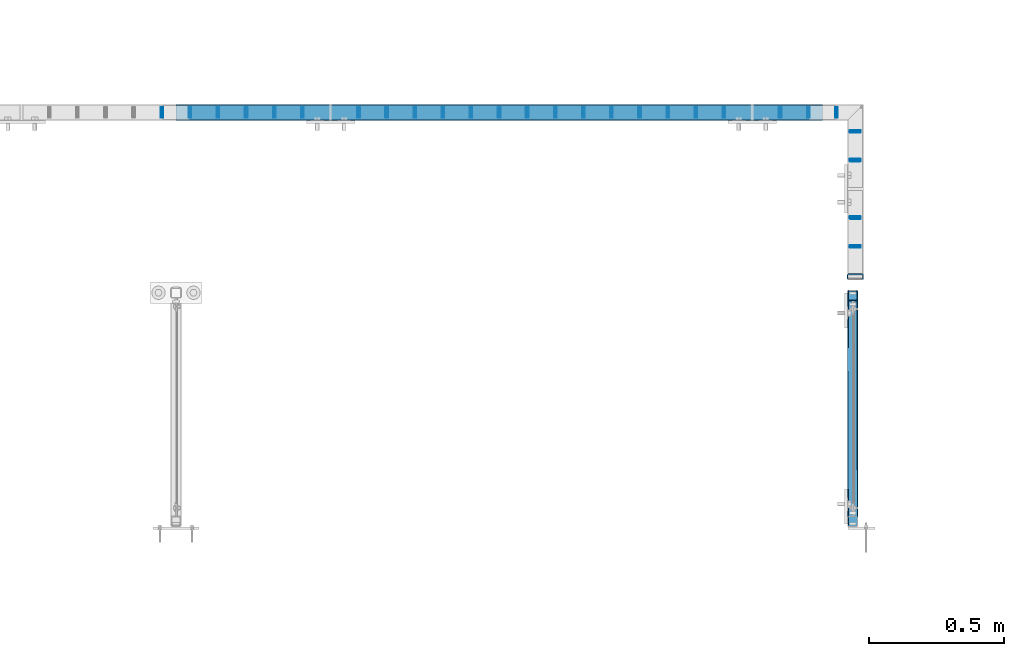
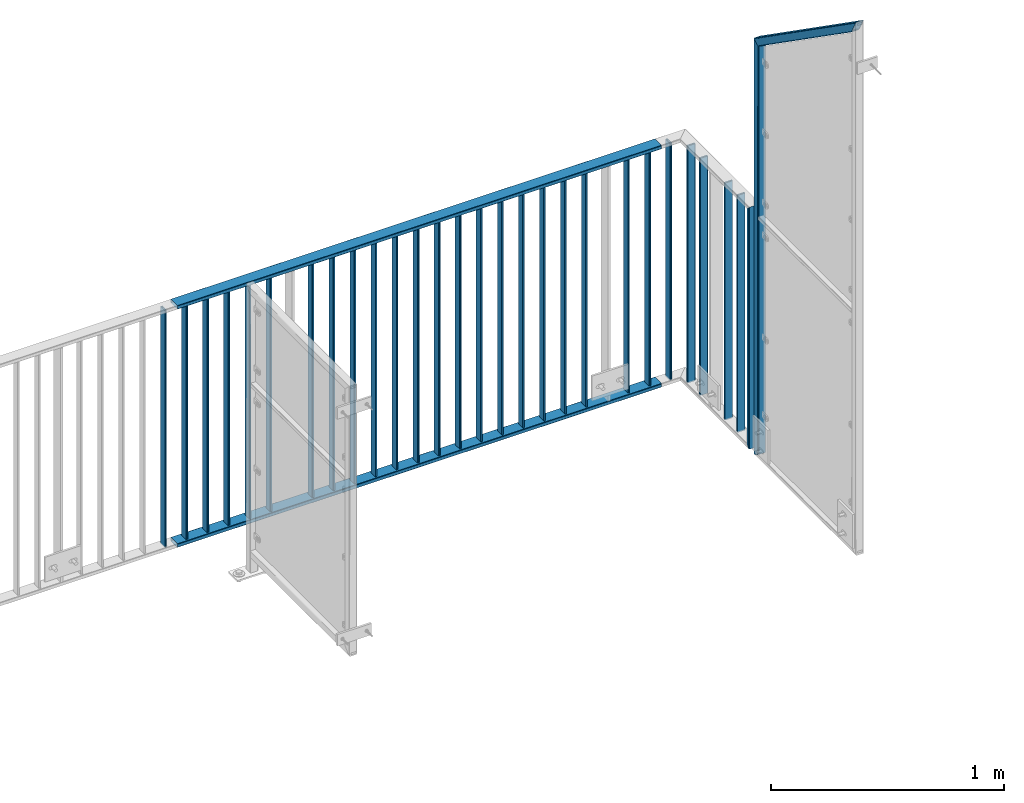
# One storey, part 35 of 156: 32 beams, 4 elements without a shape of their own.
"""IFC2X3 building model written with IfcOpenShell, lengths in millimetres."""

from ifc_helpers import new_model, si_unit, frame, origin_with_axes, origin_2d_with_axis, place, context, subcontext, project, spatial, hollow_rectangle, extrude, clip, halfspace, material, type_object, element, aggregate, save


model = new_model("IFC2X3")

# Units and contexts
model_context = context("Model", 3, precision=1e-05, world=origin_with_axes())
body_context = subcontext(model_context, "Body", "Model", "MODEL_VIEW")
ifc_project = project(units=[si_unit("LENGTHUNIT", "METRE", prefix="MILLI"), si_unit("AREAUNIT", "SQUARE_METRE"), si_unit("VOLUMEUNIT", "CUBIC_METRE"), si_unit("MASSUNIT", "GRAM", prefix="KILO"), si_unit("TIMEUNIT", "SECOND"), si_unit("PLANEANGLEUNIT", "RADIAN"), si_unit("SOLIDANGLEUNIT", "STERADIAN"), si_unit("THERMODYNAMICTEMPERATUREUNIT", "DEGREE_CELSIUS"), si_unit("LUMINOUSINTENSITYUNIT", "LUMEN")], contexts=[model_context])

# Site, building, storey
site_placement = place(None, origin_with_axes())
site = spatial("IfcSite", under=ifc_project, at=site_placement, CompositionType="ELEMENT")
building_placement = place(site_placement, origin_with_axes())
building = spatial("IfcBuilding", under=site, at=building_placement, Name="Undefined", CompositionType="ELEMENT")
storey_placement = place(building_placement, origin_with_axes())
storey = spatial("IfcBuildingStorey", under=building, at=storey_placement, Name="Undefined", CompositionType="ELEMENT", Elevation=0.0)

# Assembly, beam
assembly_1_placement = place(storey_placement, origin_with_axes())
assembly_1 = element("IfcElementAssembly", 1, at=assembly_1_placement, inside=storey, AssemblyPlace="NOTDEFINED", PredefinedType="RIGID_FRAME")
ifc_material = material(Name="STEEL/S235JR")
beam_type_1 = type_object("IfcBeamType", Name="K60/20/2", PredefinedType="NOTDEFINED")
beam_1_placement = place(assembly_1_placement, frame((46002.6731536865, 21657.990447998, 2740.0), z_axis=(0.0, -1.0, 0.0), x_axis=(-1.0, 0.0, 0.0)))
beam_1 = element("IfcBeam", 2, at=beam_1_placement, type_object=beam_type_1, material=ifc_material, ObjectType="K60/20/2", context=body_context, shape_type="SweptSolid", body=[
    extrude(hollow_rectangle(XDim=20.0, YDim=60.0, WallThickness=2.0, InnerFilletRadius=2.0, OuterFilletRadius=4.0, at=origin_2d_with_axis()), frame((2402.72054931641, 0.0, 0.0), z_axis=(-1.0, 0.0, 0.0), x_axis=(0.0, -1.0, 0.0)), (0.0, 0.0, 1.0), 2402.72),
])

assembly_2_placement = place(storey_placement, origin_with_axes())
assembly_2 = element("IfcElementAssembly", 3, at=assembly_2_placement, inside=storey, AssemblyPlace="NOTDEFINED", PredefinedType="RIGID_FRAME")
beam_2_placement = place(assembly_2_placement, frame((46124.9951324463, 21048.0001005923, 4000.0), z_axis=(-1.0, 0.0, 0.0), x_axis=(0.0, 0.0, -1.0)))
beam_2 = element("IfcBeam", 4, at=beam_2_placement, type_object=beam_type_1, material=ifc_material, ObjectType="K60/20/2", context=body_context, shape_type="Clipping", body=[
    clip(clip(extrude(hollow_rectangle(XDim=20.0, YDim=60.0, WallThickness=2.0, InnerFilletRadius=2.0, OuterFilletRadius=4.0, at=origin_2d_with_axis()), frame((1280.2, 0.0, 0.0), z_axis=(-1.0, 0.0, 0.0), x_axis=(0.0, -1.0, 0.0)), (0.0, 0.0, 1.0), 1290.4), halfspace(frame((1270.0, 10.0, 0.0), z_axis=(0.707106781186548, -0.707106781186548, 0.0), x_axis=(0.0, 0.0, -1.0)), False)), halfspace(frame((20.0, -10.0, 0.0), z_axis=(-0.707106781186548, -0.707106781186548, 0.0), x_axis=(0.0, 0.0, -1.0)), False)),
])

# Beam
beam_3_placement = place(assembly_1_placement, frame((46002.6731536865, 21657.990447998, 3990.0), z_axis=(0.0, -1.0, 0.0), x_axis=(-1.0, 0.0, 0.0)))
beam_3 = element("IfcBeam", 5, at=beam_3_placement, type_object=beam_type_1, material=ifc_material, ObjectType="K60/20/2", context=body_context, shape_type="SweptSolid", body=[
    extrude(hollow_rectangle(XDim=20.0, YDim=60.0, WallThickness=2.0, InnerFilletRadius=2.0, OuterFilletRadius=4.0, at=origin_2d_with_axis()), frame((2402.72054931641, 0.0, 0.0), z_axis=(-1.0, 0.0, 0.0), x_axis=(0.0, -1.0, 0.0)), (0.0, 0.0, 1.0), 2402.72),
])

beam_type_2 = type_object("IfcBeamType", Name="K40/10/1.5", PredefinedType="NOTDEFINED")
beam_4_placement = place(assembly_1_placement, frame((44279.0076043701, 21657.990447998, 3980.00000000003), z_axis=(0.0, -1.0, 0.0), x_axis=(0.0, 0.0, -1.0)))
beam_4 = element("IfcBeam", 6, at=beam_4_placement, type_object=beam_type_2, material=ifc_material, ObjectType="K40/10/1.5", context=body_context, shape_type="Clipping", body=[
    clip(clip(extrude(hollow_rectangle(XDim=10.0, YDim=40.0, WallThickness=1.5, InnerFilletRadius=1.5, OuterFilletRadius=3.0, at=origin_2d_with_axis()), frame((1237.00000000003, 0.0, 0.0), z_axis=(-1.0, 0.0, 0.0), x_axis=(0.0, -1.0, 0.0)), (0.0, 0.0, 1.0), 1244.0), halfspace(frame((1237.00000000003, 4.34248751949781, 47.3810900558092), z_axis=(1.0, 0.0, 0.0), x_axis=(0.0, -0.768354814194188, -0.640024124158313)), False)), halfspace(frame((-6.99999999997453, -4.34248751950508, 47.3810900558092), z_axis=(-1.0, 0.0, 0.0), x_axis=(0.0, 0.7683548141934, -0.640024124159258)), False)),
])

beam_5_placement = place(assembly_1_placement, frame((45846.0576043701, 21657.990447998, 3980.00000000003), z_axis=(0.0, -1.0, 0.0), x_axis=(0.0, 0.0, -1.0)))
beam_5 = element("IfcBeam", 7, at=beam_5_placement, type_object=beam_type_2, material=ifc_material, ObjectType="K40/10/1.5", context=body_context, shape_type="Clipping", body=[
    clip(clip(extrude(hollow_rectangle(XDim=10.0, YDim=40.0, WallThickness=1.5, InnerFilletRadius=1.5, OuterFilletRadius=3.0, at=origin_2d_with_axis()), frame((1237.00000000003, 0.0, 0.0), z_axis=(-1.0, 0.0, 0.0), x_axis=(0.0, -1.0, 0.0)), (0.0, 0.0, 1.0), 1244.0), halfspace(frame((1237.00000000003, 4.34248751949781, 47.3810900558092), z_axis=(1.0, 0.0, 0.0), x_axis=(0.0, -0.768354814194188, -0.640024124158313)), False)), halfspace(frame((-6.99999999997453, -4.34248751950508, 47.3810900558092), z_axis=(-1.0, 0.0, 0.0), x_axis=(0.0, 0.7683548141934, -0.640024124159258)), False)),
])

# Assembly, beam
assembly_3_placement = place(storey_placement, origin_with_axes())
assembly_3 = element("IfcElementAssembly", 8, at=assembly_3_placement, inside=storey, AssemblyPlace="NOTDEFINED", PredefinedType="RIGID_FRAME")
beam_6_placement = place(assembly_3_placement, frame((43547.7176043701, 21657.990447998, 3980.00000000003), z_axis=(0.0, -1.0, 0.0), x_axis=(0.0, 0.0, -1.0)))
beam_6 = element("IfcBeam", 9, at=beam_6_placement, type_object=beam_type_2, material=ifc_material, ObjectType="K40/10/1.5", context=body_context, shape_type="Clipping", body=[
    clip(clip(extrude(hollow_rectangle(XDim=10.0, YDim=40.0, WallThickness=1.5, InnerFilletRadius=1.5, OuterFilletRadius=3.0, at=origin_2d_with_axis()), frame((1237.00000000003, 0.0, 0.0), z_axis=(-1.0, 0.0, 0.0), x_axis=(0.0, -1.0, 0.0)), (0.0, 0.0, 1.0), 1244.0), halfspace(frame((1237.00000000003, 4.34248751949781, 47.3810900558092), z_axis=(1.0, 0.0, 0.0), x_axis=(0.0, -0.768354814194188, -0.640024124158313)), False)), halfspace(frame((-6.99999999997453, -4.34248751950508, 47.3810900558092), z_axis=(-1.0, 0.0, 0.0), x_axis=(0.0, 0.7683548141934, -0.640024124159258)), False)),
])
aggregate(assembly_3, [beam_6])

# Beam
beam_7_placement = place(assembly_1_placement, frame((43652.1876043701, 21657.990447998, 3980.00000000003), z_axis=(0.0, -1.0, 0.0), x_axis=(0.0, 0.0, -1.0)))
beam_7 = element("IfcBeam", 10, at=beam_7_placement, type_object=beam_type_2, material=ifc_material, ObjectType="K40/10/1.5", context=body_context, shape_type="Clipping", body=[
    clip(clip(extrude(hollow_rectangle(XDim=10.0, YDim=40.0, WallThickness=1.5, InnerFilletRadius=1.5, OuterFilletRadius=3.0, at=origin_2d_with_axis()), frame((1237.00000000003, 0.0, 0.0), z_axis=(-1.0, 0.0, 0.0), x_axis=(0.0, -1.0, 0.0)), (0.0, 0.0, 1.0), 1244.0), halfspace(frame((1237.00000000003, 4.34248751949781, 47.3810900558092), z_axis=(1.0, 0.0, 0.0), x_axis=(0.0, -0.768354814194188, -0.640024124158313)), False)), halfspace(frame((-6.99999999997453, -4.34248751950508, 47.3810900558092), z_axis=(-1.0, 0.0, 0.0), x_axis=(0.0, 0.7683548141934, -0.640024124159258)), False)),
])

beam_8_placement = place(assembly_1_placement, frame((43756.6576043701, 21657.990447998, 3980.00000000003), z_axis=(0.0, -1.0, 0.0), x_axis=(0.0, 0.0, -1.0)))
beam_8 = element("IfcBeam", 11, at=beam_8_placement, type_object=beam_type_2, material=ifc_material, ObjectType="K40/10/1.5", context=body_context, shape_type="Clipping", body=[
    clip(clip(extrude(hollow_rectangle(XDim=10.0, YDim=40.0, WallThickness=1.5, InnerFilletRadius=1.5, OuterFilletRadius=3.0, at=origin_2d_with_axis()), frame((1237.00000000003, 0.0, 0.0), z_axis=(-1.0, 0.0, 0.0), x_axis=(0.0, -1.0, 0.0)), (0.0, 0.0, 1.0), 1244.0), halfspace(frame((1237.00000000003, 4.34248751949781, 47.3810900558092), z_axis=(1.0, 0.0, 0.0), x_axis=(0.0, -0.768354814194188, -0.640024124158313)), False)), halfspace(frame((-6.99999999997453, -4.34248751950508, 47.3810900558092), z_axis=(-1.0, 0.0, 0.0), x_axis=(0.0, 0.7683548141934, -0.640024124159258)), False)),
])

beam_9_placement = place(assembly_1_placement, frame((43861.1276043701, 21657.990447998, 3980.00000000003), z_axis=(0.0, -1.0, 0.0), x_axis=(0.0, 0.0, -1.0)))
beam_9 = element("IfcBeam", 12, at=beam_9_placement, type_object=beam_type_2, material=ifc_material, ObjectType="K40/10/1.5", context=body_context, shape_type="Clipping", body=[
    clip(clip(extrude(hollow_rectangle(XDim=10.0, YDim=40.0, WallThickness=1.5, InnerFilletRadius=1.5, OuterFilletRadius=3.0, at=origin_2d_with_axis()), frame((1237.00000000003, 0.0, 0.0), z_axis=(-1.0, 0.0, 0.0), x_axis=(0.0, -1.0, 0.0)), (0.0, 0.0, 1.0), 1244.0), halfspace(frame((1237.00000000003, 4.34248751949781, 47.3810900558092), z_axis=(1.0, 0.0, 0.0), x_axis=(0.0, -0.768354814194188, -0.640024124158313)), False)), halfspace(frame((-6.99999999997453, -4.34248751950508, 47.3810900558092), z_axis=(-1.0, 0.0, 0.0), x_axis=(0.0, 0.7683548141934, -0.640024124159258)), False)),
])

beam_10_placement = place(assembly_1_placement, frame((43965.5976043701, 21657.990447998, 3980.00000000003), z_axis=(0.0, -1.0, 0.0), x_axis=(0.0, 0.0, -1.0)))
beam_10 = element("IfcBeam", 13, at=beam_10_placement, type_object=beam_type_2, material=ifc_material, ObjectType="K40/10/1.5", context=body_context, shape_type="Clipping", body=[
    clip(clip(extrude(hollow_rectangle(XDim=10.0, YDim=40.0, WallThickness=1.5, InnerFilletRadius=1.5, OuterFilletRadius=3.0, at=origin_2d_with_axis()), frame((1237.00000000003, 0.0, 0.0), z_axis=(-1.0, 0.0, 0.0), x_axis=(0.0, -1.0, 0.0)), (0.0, 0.0, 1.0), 1244.0), halfspace(frame((1237.00000000003, 4.34248751949781, 47.3810900558092), z_axis=(1.0, 0.0, 0.0), x_axis=(0.0, -0.768354814194188, -0.640024124158313)), False)), halfspace(frame((-6.99999999997453, -4.34248751950508, 47.3810900558092), z_axis=(-1.0, 0.0, 0.0), x_axis=(0.0, 0.7683548141934, -0.640024124159258)), False)),
])

beam_11_placement = place(assembly_1_placement, frame((44070.0676043701, 21657.990447998, 3980.00000000003), z_axis=(0.0, -1.0, 0.0), x_axis=(0.0, 0.0, -1.0)))
beam_11 = element("IfcBeam", 14, at=beam_11_placement, type_object=beam_type_2, material=ifc_material, ObjectType="K40/10/1.5", context=body_context, shape_type="Clipping", body=[
    clip(clip(extrude(hollow_rectangle(XDim=10.0, YDim=40.0, WallThickness=1.5, InnerFilletRadius=1.5, OuterFilletRadius=3.0, at=origin_2d_with_axis()), frame((1237.00000000003, 0.0, 0.0), z_axis=(-1.0, 0.0, 0.0), x_axis=(0.0, -1.0, 0.0)), (0.0, 0.0, 1.0), 1244.0), halfspace(frame((1237.00000000003, 4.34248751949781, 47.3810900558092), z_axis=(1.0, 0.0, 0.0), x_axis=(0.0, -0.768354814194188, -0.640024124158313)), False)), halfspace(frame((-6.99999999997453, -4.34248751950508, 47.3810900558092), z_axis=(-1.0, 0.0, 0.0), x_axis=(0.0, 0.7683548141934, -0.640024124159258)), False)),
])

beam_12_placement = place(assembly_1_placement, frame((44383.4776043701, 21657.990447998, 3980.00000000003), z_axis=(0.0, -1.0, 0.0), x_axis=(0.0, 0.0, -1.0)))
beam_12 = element("IfcBeam", 15, at=beam_12_placement, type_object=beam_type_2, material=ifc_material, ObjectType="K40/10/1.5", context=body_context, shape_type="Clipping", body=[
    clip(clip(extrude(hollow_rectangle(XDim=10.0, YDim=40.0, WallThickness=1.5, InnerFilletRadius=1.5, OuterFilletRadius=3.0, at=origin_2d_with_axis()), frame((1237.00000000003, 0.0, 0.0), z_axis=(-1.0, 0.0, 0.0), x_axis=(0.0, -1.0, 0.0)), (0.0, 0.0, 1.0), 1244.0), halfspace(frame((1237.00000000003, 4.34248751949781, 47.3810900558092), z_axis=(1.0, 0.0, 0.0), x_axis=(0.0, -0.768354814194188, -0.640024124158313)), False)), halfspace(frame((-6.99999999997453, -4.34248751950508, 47.3810900558092), z_axis=(-1.0, 0.0, 0.0), x_axis=(0.0, 0.7683548141934, -0.640024124159258)), False)),
])

beam_13_placement = place(assembly_1_placement, frame((44487.9476043701, 21657.990447998, 3980.00000000003), z_axis=(0.0, -1.0, 0.0), x_axis=(0.0, 0.0, -1.0)))
beam_13 = element("IfcBeam", 16, at=beam_13_placement, type_object=beam_type_2, material=ifc_material, ObjectType="K40/10/1.5", context=body_context, shape_type="Clipping", body=[
    clip(clip(extrude(hollow_rectangle(XDim=10.0, YDim=40.0, WallThickness=1.5, InnerFilletRadius=1.5, OuterFilletRadius=3.0, at=origin_2d_with_axis()), frame((1237.00000000003, 0.0, 0.0), z_axis=(-1.0, 0.0, 0.0), x_axis=(0.0, -1.0, 0.0)), (0.0, 0.0, 1.0), 1244.0), halfspace(frame((1237.00000000003, 4.34248751949781, 47.3810900558092), z_axis=(1.0, 0.0, 0.0), x_axis=(0.0, -0.768354814194188, -0.640024124158313)), False)), halfspace(frame((-6.99999999997453, -4.34248751950508, 47.3810900558092), z_axis=(-1.0, 0.0, 0.0), x_axis=(0.0, 0.7683548141934, -0.640024124159258)), False)),
])

beam_14_placement = place(assembly_1_placement, frame((44592.4176043701, 21657.990447998, 3980.00000000003), z_axis=(0.0, -1.0, 0.0), x_axis=(0.0, 0.0, -1.0)))
beam_14 = element("IfcBeam", 17, at=beam_14_placement, type_object=beam_type_2, material=ifc_material, ObjectType="K40/10/1.5", context=body_context, shape_type="Clipping", body=[
    clip(clip(extrude(hollow_rectangle(XDim=10.0, YDim=40.0, WallThickness=1.5, InnerFilletRadius=1.5, OuterFilletRadius=3.0, at=origin_2d_with_axis()), frame((1237.00000000003, 0.0, 0.0), z_axis=(-1.0, 0.0, 0.0), x_axis=(0.0, -1.0, 0.0)), (0.0, 0.0, 1.0), 1244.0), halfspace(frame((1237.00000000003, 4.34248751949781, 47.3810900558092), z_axis=(1.0, 0.0, 0.0), x_axis=(0.0, -0.768354814194188, -0.640024124158313)), False)), halfspace(frame((-6.99999999997453, -4.34248751950508, 47.3810900558092), z_axis=(-1.0, 0.0, 0.0), x_axis=(0.0, 0.7683548141934, -0.640024124159258)), False)),
])

beam_15_placement = place(assembly_1_placement, frame((44696.8876043701, 21657.990447998, 3980.00000000003), z_axis=(0.0, -1.0, 0.0), x_axis=(0.0, 0.0, -1.0)))
beam_15 = element("IfcBeam", 18, at=beam_15_placement, type_object=beam_type_2, material=ifc_material, ObjectType="K40/10/1.5", context=body_context, shape_type="Clipping", body=[
    clip(clip(extrude(hollow_rectangle(XDim=10.0, YDim=40.0, WallThickness=1.5, InnerFilletRadius=1.5, OuterFilletRadius=3.0, at=origin_2d_with_axis()), frame((1237.00000000003, 0.0, 0.0), z_axis=(-1.0, 0.0, 0.0), x_axis=(0.0, -1.0, 0.0)), (0.0, 0.0, 1.0), 1244.0), halfspace(frame((1237.00000000003, 4.34248751949781, 47.3810900558092), z_axis=(1.0, 0.0, 0.0), x_axis=(0.0, -0.768354814194188, -0.640024124158313)), False)), halfspace(frame((-6.99999999997453, -4.34248751950508, 47.3810900558092), z_axis=(-1.0, 0.0, 0.0), x_axis=(0.0, 0.7683548141934, -0.640024124159258)), False)),
])

beam_16_placement = place(assembly_1_placement, frame((44801.3576043701, 21657.990447998, 3980.00000000003), z_axis=(0.0, -1.0, 0.0), x_axis=(0.0, 0.0, -1.0)))
beam_16 = element("IfcBeam", 19, at=beam_16_placement, type_object=beam_type_2, material=ifc_material, ObjectType="K40/10/1.5", context=body_context, shape_type="Clipping", body=[
    clip(clip(extrude(hollow_rectangle(XDim=10.0, YDim=40.0, WallThickness=1.5, InnerFilletRadius=1.5, OuterFilletRadius=3.0, at=origin_2d_with_axis()), frame((1237.00000000003, 0.0, 0.0), z_axis=(-1.0, 0.0, 0.0), x_axis=(0.0, -1.0, 0.0)), (0.0, 0.0, 1.0), 1244.0), halfspace(frame((1237.00000000003, 4.34248751949781, 47.3810900558092), z_axis=(1.0, 0.0, 0.0), x_axis=(0.0, -0.768354814194188, -0.640024124158313)), False)), halfspace(frame((-6.99999999997453, -4.34248751950508, 47.3810900558092), z_axis=(-1.0, 0.0, 0.0), x_axis=(0.0, 0.7683548141934, -0.640024124159258)), False)),
])

beam_17_placement = place(assembly_1_placement, frame((44905.8276043701, 21657.990447998, 3980.00000000003), z_axis=(0.0, -1.0, 0.0), x_axis=(0.0, 0.0, -1.0)))
beam_17 = element("IfcBeam", 20, at=beam_17_placement, type_object=beam_type_2, material=ifc_material, ObjectType="K40/10/1.5", context=body_context, shape_type="Clipping", body=[
    clip(clip(extrude(hollow_rectangle(XDim=10.0, YDim=40.0, WallThickness=1.5, InnerFilletRadius=1.5, OuterFilletRadius=3.0, at=origin_2d_with_axis()), frame((1237.00000000003, 0.0, 0.0), z_axis=(-1.0, 0.0, 0.0), x_axis=(0.0, -1.0, 0.0)), (0.0, 0.0, 1.0), 1244.0), halfspace(frame((1237.00000000003, 4.34248751949781, 47.3810900558092), z_axis=(1.0, 0.0, 0.0), x_axis=(0.0, -0.768354814194188, -0.640024124158313)), False)), halfspace(frame((-6.99999999997453, -4.34248751950508, 47.3810900558092), z_axis=(-1.0, 0.0, 0.0), x_axis=(0.0, 0.7683548141934, -0.640024124159258)), False)),
])

beam_18_placement = place(assembly_1_placement, frame((45010.2976043701, 21657.990447998, 3980.00000000003), z_axis=(0.0, -1.0, 0.0), x_axis=(0.0, 0.0, -1.0)))
beam_18 = element("IfcBeam", 21, at=beam_18_placement, type_object=beam_type_2, material=ifc_material, ObjectType="K40/10/1.5", context=body_context, shape_type="Clipping", body=[
    clip(clip(extrude(hollow_rectangle(XDim=10.0, YDim=40.0, WallThickness=1.5, InnerFilletRadius=1.5, OuterFilletRadius=3.0, at=origin_2d_with_axis()), frame((1237.00000000003, 0.0, 0.0), z_axis=(-1.0, 0.0, 0.0), x_axis=(0.0, -1.0, 0.0)), (0.0, 0.0, 1.0), 1244.0), halfspace(frame((1237.00000000003, 4.34248751949781, 47.3810900558092), z_axis=(1.0, 0.0, 0.0), x_axis=(0.0, -0.768354814194188, -0.640024124158313)), False)), halfspace(frame((-6.99999999997453, -4.34248751950508, 47.3810900558092), z_axis=(-1.0, 0.0, 0.0), x_axis=(0.0, 0.7683548141934, -0.640024124159258)), False)),
])

beam_19_placement = place(assembly_1_placement, frame((45114.7676043701, 21657.990447998, 3980.00000000003), z_axis=(0.0, -1.0, 0.0), x_axis=(0.0, 0.0, -1.0)))
beam_19 = element("IfcBeam", 22, at=beam_19_placement, type_object=beam_type_2, material=ifc_material, ObjectType="K40/10/1.5", context=body_context, shape_type="Clipping", body=[
    clip(clip(extrude(hollow_rectangle(XDim=10.0, YDim=40.0, WallThickness=1.5, InnerFilletRadius=1.5, OuterFilletRadius=3.0, at=origin_2d_with_axis()), frame((1237.00000000003, 0.0, 0.0), z_axis=(-1.0, 0.0, 0.0), x_axis=(0.0, -1.0, 0.0)), (0.0, 0.0, 1.0), 1244.0), halfspace(frame((1237.00000000003, 4.34248751949781, 47.3810900558092), z_axis=(1.0, 0.0, 0.0), x_axis=(0.0, -0.768354814194188, -0.640024124158313)), False)), halfspace(frame((-6.99999999997453, -4.34248751950508, 47.3810900558092), z_axis=(-1.0, 0.0, 0.0), x_axis=(0.0, 0.7683548141934, -0.640024124159258)), False)),
])

beam_20_placement = place(assembly_1_placement, frame((45219.2376043701, 21657.990447998, 3980.00000000003), z_axis=(0.0, -1.0, 0.0), x_axis=(0.0, 0.0, -1.0)))
beam_20 = element("IfcBeam", 23, at=beam_20_placement, type_object=beam_type_2, material=ifc_material, ObjectType="K40/10/1.5", context=body_context, shape_type="Clipping", body=[
    clip(clip(extrude(hollow_rectangle(XDim=10.0, YDim=40.0, WallThickness=1.5, InnerFilletRadius=1.5, OuterFilletRadius=3.0, at=origin_2d_with_axis()), frame((1237.00000000003, 0.0, 0.0), z_axis=(-1.0, 0.0, 0.0), x_axis=(0.0, -1.0, 0.0)), (0.0, 0.0, 1.0), 1244.0), halfspace(frame((1237.00000000003, 4.34248751949781, 47.3810900558092), z_axis=(1.0, 0.0, 0.0), x_axis=(0.0, -0.768354814194188, -0.640024124158313)), False)), halfspace(frame((-6.99999999997453, -4.34248751950508, 47.3810900558092), z_axis=(-1.0, 0.0, 0.0), x_axis=(0.0, 0.7683548141934, -0.640024124159258)), False)),
])

beam_21_placement = place(assembly_1_placement, frame((45323.7076043701, 21657.990447998, 3980.00000000003), z_axis=(0.0, -1.0, 0.0), x_axis=(0.0, 0.0, -1.0)))
beam_21 = element("IfcBeam", 24, at=beam_21_placement, type_object=beam_type_2, material=ifc_material, ObjectType="K40/10/1.5", context=body_context, shape_type="Clipping", body=[
    clip(clip(extrude(hollow_rectangle(XDim=10.0, YDim=40.0, WallThickness=1.5, InnerFilletRadius=1.5, OuterFilletRadius=3.0, at=origin_2d_with_axis()), frame((1237.00000000003, 0.0, 0.0), z_axis=(-1.0, 0.0, 0.0), x_axis=(0.0, -1.0, 0.0)), (0.0, 0.0, 1.0), 1244.0), halfspace(frame((1237.00000000003, 4.34248751949781, 47.3810900558092), z_axis=(1.0, 0.0, 0.0), x_axis=(0.0, -0.768354814194188, -0.640024124158313)), False)), halfspace(frame((-6.99999999997453, -4.34248751950508, 47.3810900558092), z_axis=(-1.0, 0.0, 0.0), x_axis=(0.0, 0.7683548141934, -0.640024124159258)), False)),
])

beam_22_placement = place(assembly_1_placement, frame((45428.1776043701, 21657.990447998, 3980.00000000003), z_axis=(0.0, -1.0, 0.0), x_axis=(0.0, 0.0, -1.0)))
beam_22 = element("IfcBeam", 25, at=beam_22_placement, type_object=beam_type_2, material=ifc_material, ObjectType="K40/10/1.5", context=body_context, shape_type="Clipping", body=[
    clip(clip(extrude(hollow_rectangle(XDim=10.0, YDim=40.0, WallThickness=1.5, InnerFilletRadius=1.5, OuterFilletRadius=3.0, at=origin_2d_with_axis()), frame((1237.00000000003, 0.0, 0.0), z_axis=(-1.0, 0.0, 0.0), x_axis=(0.0, -1.0, 0.0)), (0.0, 0.0, 1.0), 1244.0), halfspace(frame((1237.00000000003, 4.34248751949781, 47.3810900558092), z_axis=(1.0, 0.0, 0.0), x_axis=(0.0, -0.768354814194188, -0.640024124158313)), False)), halfspace(frame((-6.99999999997453, -4.34248751950508, 47.3810900558092), z_axis=(-1.0, 0.0, 0.0), x_axis=(0.0, 0.7683548141934, -0.640024124159258)), False)),
])

beam_23_placement = place(assembly_1_placement, frame((45532.6476043701, 21657.990447998, 3980.00000000003), z_axis=(0.0, -1.0, 0.0), x_axis=(0.0, 0.0, -1.0)))
beam_23 = element("IfcBeam", 26, at=beam_23_placement, type_object=beam_type_2, material=ifc_material, ObjectType="K40/10/1.5", context=body_context, shape_type="Clipping", body=[
    clip(clip(extrude(hollow_rectangle(XDim=10.0, YDim=40.0, WallThickness=1.5, InnerFilletRadius=1.5, OuterFilletRadius=3.0, at=origin_2d_with_axis()), frame((1237.00000000003, 0.0, 0.0), z_axis=(-1.0, 0.0, 0.0), x_axis=(0.0, -1.0, 0.0)), (0.0, 0.0, 1.0), 1244.0), halfspace(frame((1237.00000000003, 4.34248751949781, 47.3810900558092), z_axis=(1.0, 0.0, 0.0), x_axis=(0.0, -0.768354814194188, -0.640024124158313)), False)), halfspace(frame((-6.99999999997453, -4.34248751950508, 47.3810900558092), z_axis=(-1.0, 0.0, 0.0), x_axis=(0.0, 0.7683548141934, -0.640024124159258)), False)),
])

beam_24_placement = place(assembly_1_placement, frame((45637.1176043701, 21657.990447998, 3980.00000000003), z_axis=(0.0, -1.0, 0.0), x_axis=(0.0, 0.0, -1.0)))
beam_24 = element("IfcBeam", 27, at=beam_24_placement, type_object=beam_type_2, material=ifc_material, ObjectType="K40/10/1.5", context=body_context, shape_type="Clipping", body=[
    clip(clip(extrude(hollow_rectangle(XDim=10.0, YDim=40.0, WallThickness=1.5, InnerFilletRadius=1.5, OuterFilletRadius=3.0, at=origin_2d_with_axis()), frame((1237.00000000003, 0.0, 0.0), z_axis=(-1.0, 0.0, 0.0), x_axis=(0.0, -1.0, 0.0)), (0.0, 0.0, 1.0), 1244.0), halfspace(frame((1237.00000000003, 4.34248751949781, 47.3810900558092), z_axis=(1.0, 0.0, 0.0), x_axis=(0.0, -0.768354814194188, -0.640024124158313)), False)), halfspace(frame((-6.99999999997453, -4.34248751950508, 47.3810900558092), z_axis=(-1.0, 0.0, 0.0), x_axis=(0.0, 0.7683548141934, -0.640024124159258)), False)),
])

beam_25_placement = place(assembly_1_placement, frame((45950.5276043701, 21657.990447998, 3980.00000000003), z_axis=(0.0, -1.0, 0.0), x_axis=(0.0, 0.0, -1.0)))
beam_25 = element("IfcBeam", 28, at=beam_25_placement, type_object=beam_type_2, material=ifc_material, ObjectType="K40/10/1.5", context=body_context, shape_type="Clipping", body=[
    clip(clip(extrude(hollow_rectangle(XDim=10.0, YDim=40.0, WallThickness=1.5, InnerFilletRadius=1.5, OuterFilletRadius=3.0, at=origin_2d_with_axis()), frame((1237.00000000003, 0.0, 0.0), z_axis=(-1.0, 0.0, 0.0), x_axis=(0.0, -1.0, 0.0)), (0.0, 0.0, 1.0), 1244.0), halfspace(frame((1237.00000000003, 4.28697690345871, 47.3348312091512), z_axis=(1.0, 0.0, 0.0), x_axis=(0.0, -0.763991285051099, -0.645226562043109)), False)), halfspace(frame((-6.99999999997453, -4.28697690345871, 47.3348312091512), z_axis=(-1.0, 0.0, 0.0), x_axis=(0.0, 0.763991285051099, -0.645226562043109)), False)),
])

aggregate(assembly_1, [beam_1, beam_4, beam_5, beam_7, beam_8, beam_9, beam_10, beam_11, beam_12, beam_13, beam_14, beam_15, beam_16, beam_17, beam_18, beam_19, beam_20, beam_21, beam_22, beam_23, beam_24, beam_25, beam_3])

beam_26_placement = place(assembly_2_placement, frame((46124.9972914954, 21160.3092182564, 3980.00000000003), z_axis=(-1.0, 0.0, 0.0), x_axis=(0.0, 0.0, -1.0)))
beam_26 = element("IfcBeam", 29, at=beam_26_placement, type_object=beam_type_2, material=ifc_material, ObjectType="K40/10/1.5", context=body_context, shape_type="Clipping", body=[
    clip(clip(extrude(hollow_rectangle(XDim=10.0, YDim=40.0, WallThickness=1.5, InnerFilletRadius=1.5, OuterFilletRadius=3.0, at=origin_2d_with_axis()), frame((1237.00000000003, 0.0, 0.0), z_axis=(-1.0, 0.0, 0.0), x_axis=(0.0, -1.0, 0.0)), (0.0, 0.0, 1.0), 1244.0), halfspace(frame((1237.00000000003, 3.2449841921989, 46.4665039507236), z_axis=(1.0, 0.0, 0.0), x_axis=(0.0, -0.754414263122933, -0.656398598106883)), False)), halfspace(frame((-6.99999999997453, -2.66359292875859, 45.9820112315028), z_axis=(-1.0, 0.0, 0.0), x_axis=(0.0, 0.747680594279002, -0.664058528247773)), False)),
])

beam_27_placement = place(assembly_2_placement, frame((46124.9972914954, 21267.2292182564, 3980.00000000003), z_axis=(-1.0, 0.0, 0.0), x_axis=(0.0, 0.0, -1.0)))
beam_27 = element("IfcBeam", 30, at=beam_27_placement, type_object=beam_type_2, material=ifc_material, ObjectType="K40/10/1.5", context=body_context, shape_type="Clipping", body=[
    clip(clip(extrude(hollow_rectangle(XDim=10.0, YDim=40.0, WallThickness=1.5, InnerFilletRadius=1.5, OuterFilletRadius=3.0, at=origin_2d_with_axis()), frame((1237.00000000003, 0.0, 0.0), z_axis=(-1.0, 0.0, 0.0), x_axis=(0.0, -1.0, 0.0)), (0.0, 0.0, 1.0), 1244.0), halfspace(frame((1237.00000000003, 2.66359292875859, 45.9820112315028), z_axis=(1.0, 0.0, 0.0), x_axis=(0.0, -0.747680594278991, -0.664058528247785)), False)), halfspace(frame((-6.99999999997453, -2.66359292875859, 45.9820112315028), z_axis=(-1.0, 0.0, 0.0), x_axis=(0.0, 0.747680594279002, -0.664058528247773)), False)),
])

beam_28_placement = place(assembly_2_placement, frame((46124.9972914954, 21481.0692182564, 3980.00000000003), z_axis=(-1.0, 0.0, 0.0), x_axis=(0.0, 0.0, -1.0)))
beam_28 = element("IfcBeam", 31, at=beam_28_placement, type_object=beam_type_2, material=ifc_material, ObjectType="K40/10/1.5", context=body_context, shape_type="Clipping", body=[
    clip(clip(extrude(hollow_rectangle(XDim=10.0, YDim=40.0, WallThickness=1.5, InnerFilletRadius=1.5, OuterFilletRadius=3.0, at=origin_2d_with_axis()), frame((1237.00000000003, 0.0, 0.0), z_axis=(-1.0, 0.0, 0.0), x_axis=(0.0, -1.0, 0.0)), (0.0, 0.0, 1.0), 1244.0), halfspace(frame((1237.00000000003, 2.66359292875859, 45.9820112315028), z_axis=(1.0, 0.0, 0.0), x_axis=(0.0, -0.747680594278991, -0.664058528247785)), False)), halfspace(frame((-6.99999999997453, -2.66359292875859, 45.9820112315028), z_axis=(-1.0, 0.0, 0.0), x_axis=(0.0, 0.747680594279002, -0.664058528247773)), False)),
])

beam_29_placement = place(assembly_2_placement, frame((46054.9976043701, 21657.990447998, 3980.00000000003), z_axis=(0.0, -1.0, 0.0), x_axis=(0.0, 0.0, -1.0)))
beam_29 = element("IfcBeam", 32, at=beam_29_placement, type_object=beam_type_2, material=ifc_material, ObjectType="K40/10/1.5", context=body_context, shape_type="Clipping", body=[
    clip(clip(extrude(hollow_rectangle(XDim=10.0, YDim=40.0, WallThickness=1.5, InnerFilletRadius=1.5, OuterFilletRadius=3.0, at=origin_2d_with_axis()), frame((1237.00000000003, 0.0, 0.0), z_axis=(-1.0, 0.0, 0.0), x_axis=(0.0, -1.0, 0.0)), (0.0, 0.0, 1.0), 1244.0), halfspace(frame((1237.00000000003, 4.34248751949781, 47.3810900558092), z_axis=(1.0, 0.0, 0.0), x_axis=(0.0, -0.763991285051099, -0.645226562043109)), False)), halfspace(frame((-6.99999999997453, -4.34248751950508, 47.3810900558092), z_axis=(-1.0, 0.0, 0.0), x_axis=(0.0, 0.763991285051099, -0.645226562043109)), False)),
])

beam_30_placement = place(assembly_2_placement, frame((46124.9972914954, 21587.9892182564, 3980.00000000003), z_axis=(-1.0, 0.0, 0.0), x_axis=(0.0, 0.0, -1.0)))
beam_30 = element("IfcBeam", 33, at=beam_30_placement, type_object=beam_type_2, material=ifc_material, ObjectType="K40/10/1.5", context=body_context, shape_type="Clipping", body=[
    clip(clip(extrude(hollow_rectangle(XDim=10.0, YDim=40.0, WallThickness=1.5, InnerFilletRadius=1.5, OuterFilletRadius=3.0, at=origin_2d_with_axis()), frame((1237.00000000003, 0.0, 0.0), z_axis=(-1.0, 0.0, 0.0), x_axis=(0.0, -1.0, 0.0)), (0.0, 0.0, 1.0), 1244.0), halfspace(frame((1237.00000000003, 1.80362172154128, 45.2653685592795), z_axis=(1.0, 0.0, 0.0), x_axis=(0.0, -0.737586551668085, -0.675252603696115)), False)), halfspace(frame((-6.99999999997453, -1.80362172153764, 45.2653685592795), z_axis=(-1.0, 0.0, 0.0), x_axis=(0.0, 0.737586551668074, -0.675252603696127)), False)),
])

aggregate(assembly_2, [beam_26, beam_27, beam_28, beam_29, beam_2, beam_30])

# Assembly, beams
assembly_4_placement = place(storey_placement, origin_with_axes())
assembly_4 = element("IfcElementAssembly", 34, at=assembly_4_placement, inside=storey, AssemblyPlace="NOTDEFINED", PredefinedType="RIGID_FRAME")
beam_type_3 = type_object("IfcBeamType", Name="K40/3", PredefinedType="NOTDEFINED")
beam_31_placement = place(assembly_4_placement, frame((46114.9951324463, 20978.0015659802, 4933.35224486177), z_axis=(1.0, 0.0, 0.0), x_axis=(0.0, 1.73100000029081e-06, -0.999999999998502)))
beam_31 = element("IfcBeam", 35, at=beam_31_placement, type_object=beam_type_3, material=ifc_material, ObjectType="K40/3", context=body_context, shape_type="Clipping", body=[
    clip(clip(extrude(hollow_rectangle(XDim=40.0, YDim=40.0, WallThickness=3.0, InnerFilletRadius=3.0, OuterFilletRadius=6.0, at=origin_2d_with_axis()), frame((2213.96778066274, 0.0, 0.0), z_axis=(-1.0, 0.0, 0.0), x_axis=(0.0, -1.0, 0.0)), (0.0, 0.0, 1.0), 2204.17), halfspace(frame((2183.35221024504, -19.999999997337, 0.0), z_axis=(-0.894426571672334, 0.447214834152978, 0.0), x_axis=(0.0, 0.0, -1.0)), True)), halfspace(frame((20.000024231771, 20.00000000004, 0.0), z_axis=(0.887011256231877, 0.461747800555614, 0.0), x_axis=(0.0, 0.0, -1.0)), True)),
])
beam_32_placement = place(assembly_4_placement, frame((46114.9951324463, 20096.5306460328, 5520.15365547741), z_axis=(0.0, 0.573576519196191, 0.819151986280191), x_axis=(0.0, 0.81915198628019, -0.573576519196192)))
beam_32 = element("IfcBeam", 36, at=beam_32_placement, type_object=beam_type_3, material=ifc_material, ObjectType="K40/3", context=body_context, shape_type="Clipping", body=[
    clip(clip(extrude(hollow_rectangle(XDim=40.0, YDim=40.0, WallThickness=3.0, InnerFilletRadius=3.0, OuterFilletRadius=6.0, at=origin_2d_with_axis()), frame((1137.4595634918, 0.0, 0.0), z_axis=(-1.0, 0.0, 0.0), x_axis=(0.0, -1.0, 0.0)), (0.0, 0.0, 1.0), 1148.21), halfspace(frame((1086.4887579936, 0.0, 20.0000000033942), z_axis=(0.887011256109767, 0.0, -0.461747800790186), x_axis=(0.0, 1.0, 0.0)), False)), halfspace(frame((12.2077467483559, 0.0, 20.0000000013606), z_axis=(0.461748568874198, 0.0, 0.88701085627101), x_axis=(0.0, 1.0, 0.0)), True)),
])
aggregate(assembly_4, [beam_31, beam_32])

save(model, "model.ifc")
